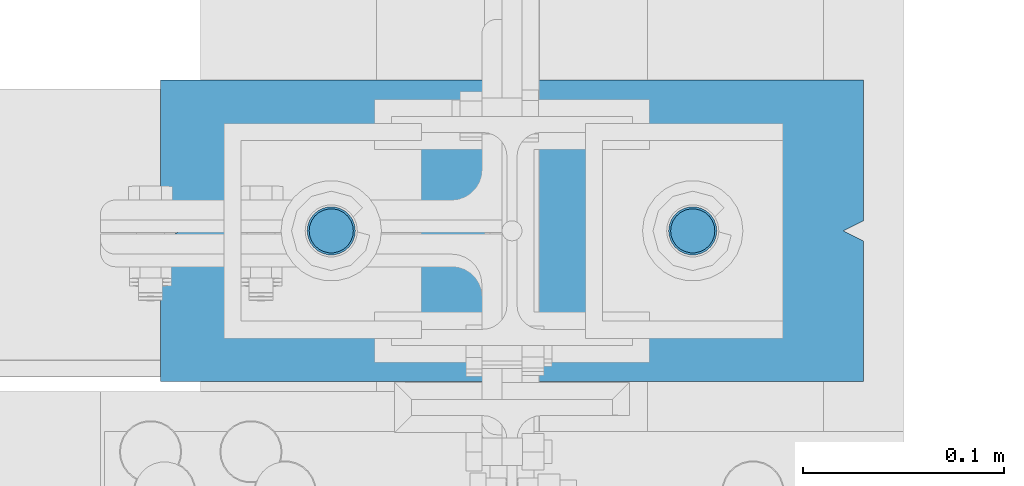
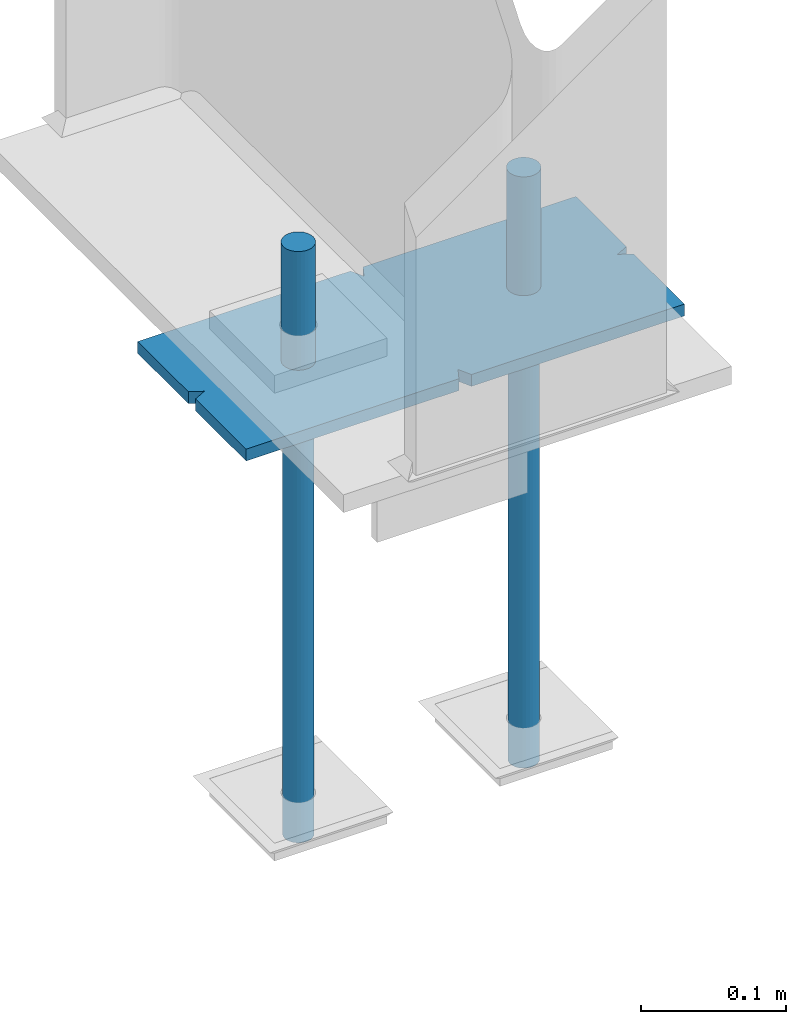
# One storey, part 105 of 496: 5 beams, 1 element without a shape of its own.
"""IFC2X3 building model written with IfcOpenShell, lengths in millimetres."""

from ifc_helpers import new_model, si_unit, frame, origin_with_axes, origin_2d_with_axis, place, context, subcontext, project, spatial, polyline, rectangle, circle, outline, extrude, boolean, material, type_object, element, aggregate, save


model = new_model("IFC2X3")

# Units and contexts
model_context = context("Model", 3, precision=1e-05, world=origin_with_axes())
body_context = subcontext(model_context, "Body", "Model", "MODEL_VIEW")
ifc_project = project(units=[si_unit("LENGTHUNIT", "METRE", prefix="MILLI"), si_unit("AREAUNIT", "SQUARE_METRE"), si_unit("VOLUMEUNIT", "CUBIC_METRE"), si_unit("MASSUNIT", "GRAM", prefix="KILO"), si_unit("TIMEUNIT", "SECOND"), si_unit("PLANEANGLEUNIT", "RADIAN"), si_unit("SOLIDANGLEUNIT", "STERADIAN"), si_unit("THERMODYNAMICTEMPERATUREUNIT", "DEGREE_CELSIUS"), si_unit("LUMINOUSINTENSITYUNIT", "LUMEN")], contexts=[model_context])

# Site, building, storey
site_placement = place(None, origin_with_axes())
site = spatial("IfcSite", under=ifc_project, at=site_placement, CompositionType="ELEMENT")
building_placement = place(site_placement, origin_with_axes())
building = spatial("IfcBuilding", under=site, at=building_placement, Name="Undefined", CompositionType="ELEMENT")
storey_placement = place(building_placement, origin_with_axes())
storey = spatial("IfcBuildingStorey", under=building, at=storey_placement, Name="Undefined", CompositionType="ELEMENT", Elevation=0.0)

# Assembly, beams
assembly_placement = place(storey_placement, origin_with_axes())
assembly = element("IfcElementAssembly", 1, at=assembly_placement, inside=storey, Name="PS24", AssemblyPlace="NOTDEFINED", PredefinedType="NOTDEFINED")
ifc_material = material(Name="Undefined/S235-E24")
beam_type_1 = type_object("IfcBeamType", Name="D24", PredefinedType="NOTDEFINED")
beam_1_placement = place(assembly_placement, frame((39539.9971504447, 0.0, -100.0), z_axis=(0.0, 1.0, 0.0), x_axis=(0.0, 0.0, -1.0)))
beam_1 = element("IfcBeam", 2, at=beam_1_placement, type_object=beam_type_1, material=ifc_material, ObjectType="D24", context=body_context, shape_type="SweptSolid", body=[
    extrude(circle(Radius=12.0, at=origin_2d_with_axis()), frame((149.999995982835, 4.54747350886464e-12, 3.63797880709171e-12), z_axis=(-1.0, 0.0, 0.0), x_axis=(0.0, -1.0, 0.0)), (0.0, 0.0, 1.0), 150.0),
])
beam_2_placement = place(assembly_placement, frame((39719.9971504447, 0.0, -100.0), z_axis=(0.0, 1.0, 0.0), x_axis=(0.0, 0.0, -1.0)))
beam_2 = element("IfcBeam", 3, at=beam_2_placement, type_object=beam_type_1, material=ifc_material, ObjectType="D24", context=body_context, shape_type="SweptSolid", body=[
    extrude(circle(Radius=12.0, at=origin_2d_with_axis()), frame((149.999995982835, 4.54747350886464e-12, 3.63797880709171e-12), z_axis=(-1.0, 0.0, 0.0), x_axis=(0.0, -1.0, 0.0)), (0.0, 0.0, 1.0), 150.0),
])
beam_type_2 = type_object("IfcBeamType", Name="D22", PredefinedType="NOTDEFINED")
beam_3_placement = place(assembly_placement, frame((39539.9971504447, 0.0, -250.0), z_axis=(0.0, 1.0, 0.0), x_axis=(0.0, 0.0, -1.0)))
beam_3 = element("IfcBeam", 4, at=beam_3_placement, type_object=beam_type_2, material=ifc_material, ObjectType="D22", context=body_context, shape_type="SweptSolid", body=[
    extrude(circle(Radius=11.0, at=origin_2d_with_axis()), frame((350.0, 0.0, 0.0), z_axis=(-1.0, 0.0, 0.0), x_axis=(0.0, -1.0, 0.0)), (0.0, 0.0, 1.0), 350.0),
])
beam_4_placement = place(assembly_placement, frame((39719.9971504447, 0.0, -250.0), z_axis=(0.0, 1.0, 0.0), x_axis=(0.0, 0.0, -1.0)))
beam_4 = element("IfcBeam", 5, at=beam_4_placement, type_object=beam_type_2, material=ifc_material, ObjectType="D22", context=body_context, shape_type="SweptSolid", body=[
    extrude(circle(Radius=11.0, at=origin_2d_with_axis()), frame((350.0, 0.0, 0.0), z_axis=(-1.0, 0.0, 0.0), x_axis=(0.0, -1.0, 0.0)), (0.0, 0.0, 1.0), 350.0),
])
beam_type_3 = type_object("IfcBeamType", PredefinedType="NOTDEFINED")
beam_5_placement = place(assembly_placement, frame((39805.0, 0.0, -205.0), z_axis=(0.0, -1.0, 0.0), x_axis=(-1.0, 0.0, 0.0)))
beam_5 = element("IfcBeam", 6, at=beam_5_placement, type_object=beam_type_3, material=ifc_material, Name="PS24", context=body_context, shape_type="CSG", body=[
    boolean("DIFFERENCE", boolean("DIFFERENCE", boolean("DIFFERENCE", boolean("DIFFERENCE", extrude(rectangle(XDim=10.0, YDim=150.0, at=origin_2d_with_axis()), frame((350.0, 0.0, 0.0), z_axis=(-1.0, 0.0, 0.0), x_axis=(0.0, -1.0, 0.0)), (0.0, 0.0, 1.0), 350.0), extrude(outline(polyline([(0.0, 0.0), (11.1803398132297, 1.2732925824821e-11), (4.47213602066586, 8.94427204135718), (0.0, 0.0)])), frame((0.0, 7.5, -5.0), z_axis=(0.0, -1.0, 0.0), x_axis=(0.894427191199935, 0.0, 0.44721359509992)), (0.0, 0.0, 1.0), 15.0)), extrude(outline(polyline([(0.0, 0.0), (11.1803398132297, 1.2732925824821e-11), (4.47213602066586, 8.94427204135718), (0.0, 0.0)])), frame((180.0, 7.5, -75.0), z_axis=(0.0, -1.0, 0.0), x_axis=(-0.447213595099959, 0.0, 0.894427191199915)), (0.0, 0.0, 1.0), 15.0)), extrude(outline(polyline([(0.0, 0.0), (11.1803398132297, 1.2732925824821e-11), (6.70820379256475, 8.94427204134627), (0.0, 0.0)])), frame((340.0, 7.5, 0.0), z_axis=(0.0, -1.0, 0.0), x_axis=(0.894427191199935, 0.0, -0.44721359509992)), (0.0, 0.0, 1.0), 15.0)), extrude(outline(polyline([(0.0, 0.0), (11.1803398132297, 1.2732925824821e-11), (4.47213602066586, 8.94427204135718), (0.0, 0.0)])), frame((170.0, 7.5, 75.0), z_axis=(0.0, -1.0, 0.0), x_axis=(0.447213595099959, 0.0, -0.894427191199915)), (0.0, 0.0, 1.0), 15.0)),
])
aggregate(assembly, [beam_1, beam_3, beam_2, beam_4, beam_5])

save(model, "model.ifc")
